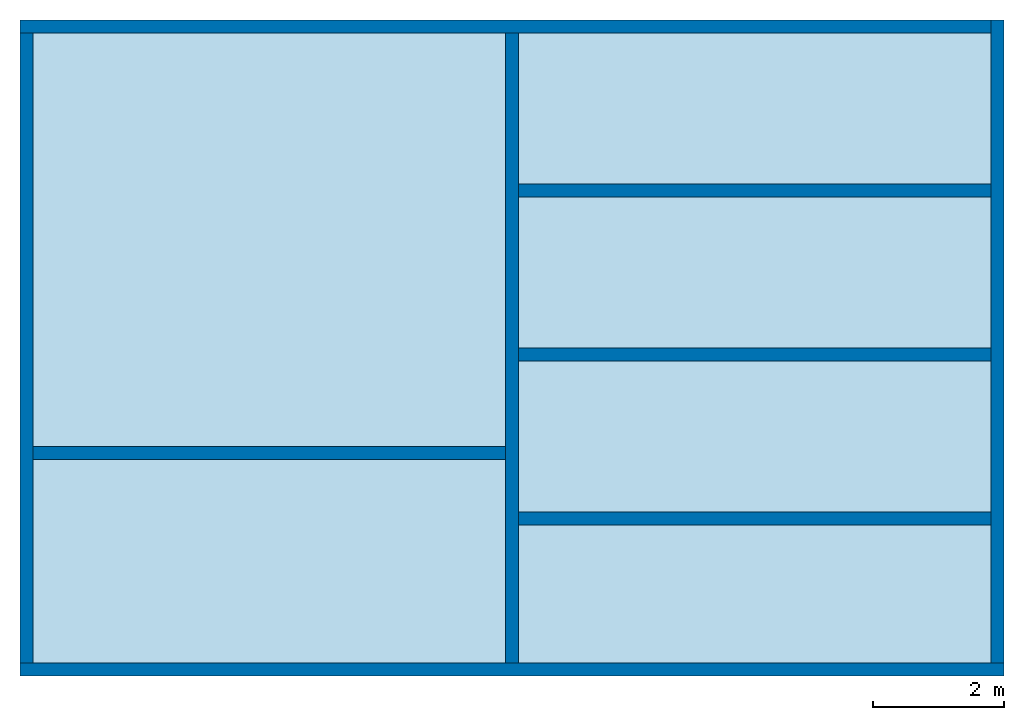
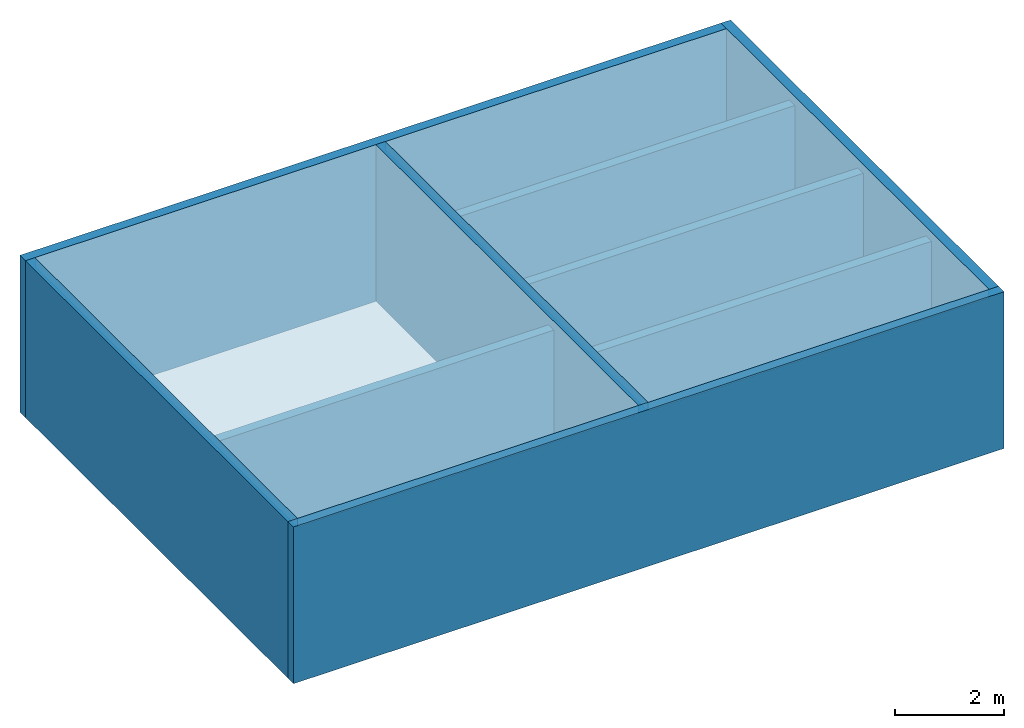
# One storey: 9 walls, 2 slabs.
"""IFC2X3 building model written with IfcOpenShell, lengths in metres."""

from ifc_helpers import new_model, entity, si_unit, converted_unit, frame, frame_2d, origin, origin_with_axes, place, context, subcontext, project, spatial, rectangle, extrude, material, layer, layer_set, layer_usage, element, save


model = new_model("IFC2X3")

# Units and contexts
model_context = context("Model", 3, precision=1e-05, world=origin())
body_context = subcontext(model_context, "Body", "Model", "MODEL_VIEW")
ifc_project = project(units=[si_unit("LENGTHUNIT", "METRE"), si_unit("AREAUNIT", "SQUARE_METRE"), si_unit("VOLUMEUNIT", "CUBIC_METRE"), converted_unit("PLANEANGLEUNIT", "DEGREE", entity("IfcPlaneAngleMeasure", 0.0174532925199433), si_unit("PLANEANGLEUNIT", "RADIAN"), dimensions=[0, 0, 0, 0, 0, 0, 0])], contexts=[model_context])

# Site, building, storey
site_placement = place(None, frame((2.0, 7.0, 6.0)))
site = spatial("IfcSite", under=ifc_project, at=site_placement, CompositionType="ELEMENT")
building_placement = place(site_placement, origin())
building = spatial("IfcBuilding", under=site, at=building_placement, Name="de", CompositionType="ELEMENT")
storey_placement = place(building_placement, frame((0.0, 0.0, 4.0)))
storey = spatial("IfcBuildingStorey", under=building, at=storey_placement, CompositionType="ELEMENT", Elevation=4.0)

# Slabs
ifc_material_1 = material()
slab_1_placement = place(storey_placement, frame((-5.951562500000001, -1.533020833333332, 3.3)))
element("IfcSlab", 1, at=slab_1_placement, inside=storey, material=ifc_material_1, PredefinedType="FLOOR", context=body_context, shape_type="SweptSolid", body=[
    extrude(rectangle(XDim=9.6, YDim=7.199999999999998, at=frame_2d((3.599999999999999, -4.8), x_axis=(0.0, -1.0))), frame((0.0, 9.6, 0.0), z_axis=(0.0, 0.0, 1.0), x_axis=(1.0, 0.0, 0.0)), (0.0, 0.0, 1.0), 0.2),
])
ifc_material_2 = material()
slab_2_placement = place(storey_placement, frame((1.448437499999999, -1.533020833333332, 3.3)))
element("IfcSlab", 2, at=slab_2_placement, inside=storey, material=ifc_material_2, PredefinedType="FLOOR", context=body_context, shape_type="SweptSolid", body=[
    extrude(rectangle(XDim=9.6, YDim=7.200000000000001, at=frame_2d((3.600000000000001, -4.8), x_axis=(0.0, -1.0))), frame((0.0, 9.6, 0.0), z_axis=(0.0, 0.0, 1.0), x_axis=(1.0, 0.0, 0.0)), (0.0, 0.0, 1.0), 0.2),
])

# Walls
ifc_material_3 = material()
ifc_layer_1 = layer(ifc_material_3, 0.2)
ifc_layer_set_1 = layer_set([ifc_layer_1])
ifc_layer_usage_1 = layer_usage(ifc_layer_set_1, "AXIS2", "POSITIVE", 0.0)
wall_1_placement = place(storey_placement, frame((-6.1515625, -1.733020833333332, 0.0)))
element("IfcWallStandardCase", 3, at=wall_1_placement, inside=storey, material=ifc_layer_usage_1, context=body_context, shape_type="SweptSolid", body=[
    extrude(rectangle(XDim=15.0, YDim=0.2, at=frame_2d((7.5, 0.1), x_axis=(1.0, 0.0))), origin_with_axes(), (0.0, 0.0, 1.0), 3.5),
])
ifc_material_4 = material()
ifc_layer_2 = layer(ifc_material_4, 0.2)
ifc_layer_set_2 = layer_set([ifc_layer_2])
ifc_layer_usage_2 = layer_usage(ifc_layer_set_2, "AXIS2", "POSITIVE", 0.0)
wall_2_placement = place(storey_placement, frame((8.848437500000001, -1.533020833333332, 0.0), z_axis=(0.0, 0.0, 1.0), x_axis=(0.0, 1.0, 0.0)))
element("IfcWallStandardCase", 4, at=wall_2_placement, inside=storey, material=ifc_layer_usage_2, context=body_context, shape_type="SweptSolid", body=[
    extrude(rectangle(XDim=9.8, YDim=0.2, at=frame_2d((4.9, 0.1), x_axis=(1.0, 0.0))), origin_with_axes(), (0.0, 0.0, 1.0), 3.5),
])
ifc_material_5 = material()
ifc_layer_3 = layer(ifc_material_5, 0.2)
ifc_layer_set_3 = layer_set([ifc_layer_3])
ifc_layer_usage_3 = layer_usage(ifc_layer_set_3, "AXIS2", "POSITIVE", 0.0)
wall_3_placement = place(storey_placement, frame((8.6484375, 8.266979166666667, 0.0), z_axis=(0.0, 0.0, 1.0), x_axis=(-1.0, 0.0, 0.0)))
element("IfcWallStandardCase", 5, at=wall_3_placement, inside=storey, material=ifc_layer_usage_3, context=body_context, shape_type="SweptSolid", body=[
    extrude(rectangle(XDim=14.8, YDim=0.2, at=frame_2d((7.4, 0.1), x_axis=(1.0, 0.0))), origin_with_axes(), (0.0, 0.0, 1.0), 3.5),
])
ifc_material_6 = material()
ifc_layer_4 = layer(ifc_material_6, 0.2)
ifc_layer_set_4 = layer_set([ifc_layer_4])
ifc_layer_usage_4 = layer_usage(ifc_layer_set_4, "AXIS2", "POSITIVE", 0.0)
wall_4_placement = place(storey_placement, frame((-6.1515625, 8.066979166666668, 0.0), z_axis=(0.0, 0.0, 1.0), x_axis=(0.0, -1.0, 0.0)))
element("IfcWallStandardCase", 6, at=wall_4_placement, inside=storey, material=ifc_layer_usage_4, context=body_context, shape_type="SweptSolid", body=[
    extrude(rectangle(XDim=9.6, YDim=0.2, at=frame_2d((4.8, 0.1), x_axis=(1.0, 0.0))), origin_with_axes(), (0.0, 0.0, 1.0), 3.5),
])
ifc_material_7 = material()
ifc_layer_5 = layer(ifc_material_7, 0.2)
ifc_layer_set_5 = layer_set([ifc_layer_5])
ifc_layer_usage_5 = layer_usage(ifc_layer_set_5, "AXIS2", "POSITIVE", -0.1)
wall_5_placement = place(storey_placement, frame((1.248437499999999, 8.066979166666668, 0.0), z_axis=(0.0, 0.0, 1.0), x_axis=(-1.894780628693601e-16, -1.0, 0.0)))
element("IfcWallStandardCase", 7, at=wall_5_placement, inside=storey, material=ifc_layer_usage_5, context=body_context, shape_type="SweptSolid", body=[
    extrude(rectangle(XDim=9.6, YDim=0.2, at=frame_2d((4.8, 0.1), x_axis=(1.0, 0.0))), origin_with_axes(), (0.0, 0.0, 1.0), 3.5),
])
ifc_material_8 = material()
ifc_layer_6 = layer(ifc_material_8, 0.2)
ifc_layer_set_6 = layer_set([ifc_layer_6])
ifc_layer_usage_6 = layer_usage(ifc_layer_set_6, "AXIS2", "POSITIVE", -0.1)
wall_6_placement = place(storey_placement, frame((1.448437499999999, 5.566979166666669, 0.0), z_axis=(0.0, 0.0, 1.0), x_axis=(0.9999999999999999, -2.526374171591467e-16, 0.0)))
element("IfcWallStandardCase", 8, at=wall_6_placement, inside=storey, material=ifc_layer_usage_6, context=body_context, shape_type="SweptSolid", body=[
    extrude(rectangle(XDim=7.200000000000001, YDim=0.2, at=frame_2d((3.600000000000001, 0.09999999999999999), x_axis=(1.0, 0.0))), origin_with_axes(), (0.0, 0.0, 1.0), 3.3),
])
ifc_material_9 = material()
ifc_layer_7 = layer(ifc_material_9, 0.2)
ifc_layer_set_7 = layer_set([ifc_layer_7])
ifc_layer_usage_7 = layer_usage(ifc_layer_set_7, "AXIS2", "POSITIVE", -0.1)
wall_7_placement = place(storey_placement, frame((1.4484375, 3.06697916666667, 0.0), z_axis=(0.0, 0.0, 1.0), x_axis=(1.0, -2.526374171591467e-16, 0.0)))
element("IfcWallStandardCase", 9, at=wall_7_placement, inside=storey, material=ifc_layer_usage_7, context=body_context, shape_type="SweptSolid", body=[
    extrude(rectangle(XDim=7.2, YDim=0.2, at=frame_2d((3.6, 0.1), x_axis=(1.0, 0.0))), origin_with_axes(), (0.0, 0.0, 1.0), 3.3),
])
ifc_material_10 = material()
ifc_layer_8 = layer(ifc_material_10, 0.2)
ifc_layer_set_8 = layer_set([ifc_layer_8])
ifc_layer_usage_8 = layer_usage(ifc_layer_set_8, "AXIS2", "POSITIVE", -0.1)
wall_8_placement = place(storey_placement, frame((1.4484375, 0.5669791666666706, 0.0), z_axis=(0.0, 0.0, 1.0), x_axis=(1.0, -2.526374171591467e-16, 0.0)))
element("IfcWallStandardCase", 10, at=wall_8_placement, inside=storey, material=ifc_layer_usage_8, context=body_context, shape_type="SweptSolid", body=[
    extrude(rectangle(XDim=7.2, YDim=0.2, at=frame_2d((3.6, 0.1), x_axis=(1.0, 0.0))), origin_with_axes(), (0.0, 0.0, 1.0), 3.3),
])
ifc_material_11 = material()
ifc_layer_9 = layer(ifc_material_11, 0.2)
ifc_layer_set_9 = layer_set([ifc_layer_9])
ifc_layer_usage_9 = layer_usage(ifc_layer_set_9, "AXIS2", "POSITIVE", -0.1)
wall_9_placement = place(storey_placement, frame((1.248437499999998, 1.766979166666668, 0.0), z_axis=(0.0, 0.0, 1.0), x_axis=(-1.0, 0.0, 0.0)))
element("IfcWallStandardCase", 11, at=wall_9_placement, inside=storey, material=ifc_layer_usage_9, context=body_context, shape_type="SweptSolid", body=[
    extrude(rectangle(XDim=7.2, YDim=0.2, at=frame_2d((3.6, 0.1), x_axis=(1.0, 0.0))), origin_with_axes(), (0.0, 0.0, 1.0), 3.3),
])

save(model, "model.ifc")
